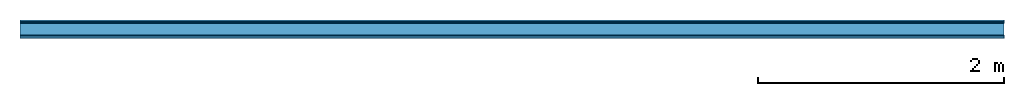
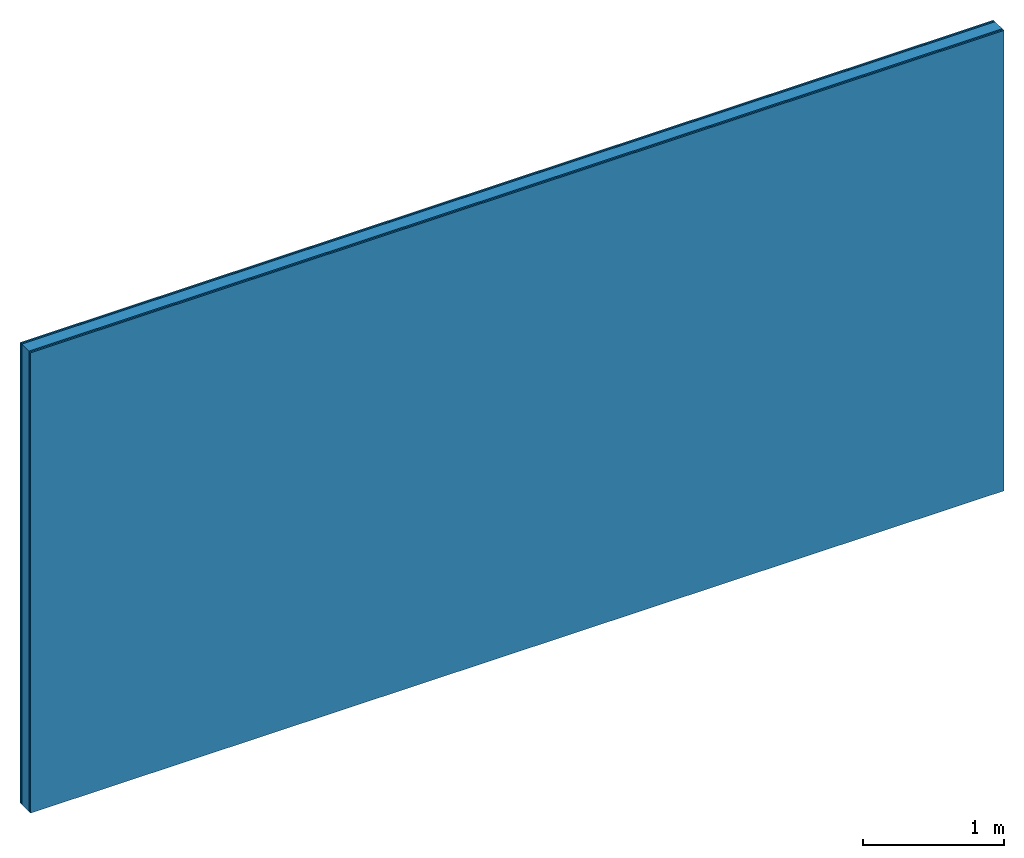
# One storey: 4 plates, 1 member, 1 element without a shape of its own.
"""IFC4 building model written with IfcOpenShell, lengths in metres."""

from ifc_helpers import new_model, si_unit, derived_unit, direction, frame, frame_2d, origin, origin_with_axes, place, context, project, spatial, rectangle, extrude, material, layer, layer_set, type_object, element, aggregate, save


model = new_model("IFC4")

# Units and contexts
plan_context = context("Plan", 3, precision=1e-05, world=origin(), true_north=direction((0.0, 1.0)))
model_context = context("Model", 3, precision=1e-05, world=origin(), true_north=direction((0.0, 1.0)))
ifc_project = project(units=[si_unit("LENGTHUNIT", "METRE"), derived_unit("SOUNDPRESSUREUNIT", [(si_unit("PRESSUREUNIT", "PASCAL", prefix="MICRO"), 0)]), si_unit("ENERGYUNIT", "JOULE", prefix="MEGA"), si_unit("MASSUNIT", "GRAM", prefix="KILO"), derived_unit("THERMALTRANSMITTANCEUNIT", [(si_unit("POWERUNIT", "WATT"), 1), (si_unit("AREAUNIT", "SQUARE_METRE"), -1), (si_unit("THERMODYNAMICTEMPERATUREUNIT", "KELVIN"), -1)]), derived_unit("AREADENSITYUNIT", [(si_unit("MASSUNIT", "GRAM", prefix="KILO"), 1), (si_unit("AREAUNIT", "SQUARE_METRE"), -1)]), derived_unit("USERDEFINED", [(si_unit("ENERGYUNIT", "JOULE", prefix="MEGA"), 1), (si_unit("AREAUNIT", "SQUARE_METRE"), -1)])], contexts=[plan_context, model_context])

# Site, building, storey
site = spatial("IfcSite", under=ifc_project)
building_placement = place(None, origin())
building = spatial("IfcBuilding", under=site, at=building_placement)
storey_placement = place(building_placement, origin())
storey = spatial("IfcBuildingStorey", under=building, at=storey_placement)

# Wall, member, plates
ifc_material_1 = material(Name="joints", Category="04.017")
ifc_layer_1 = layer(ifc_material_1, 0.0, Name="Surface")
ifc_material_2 = material(Name="Rigidur H", Category="03.007")
ifc_layer_2 = layer(ifc_material_2, 0.0125, Name="2nd layer")
ifc_layer_3 = layer(ifc_material_2, 0.0125, Name="1st layer")
ifc_material_3 = material(Name="of the art")
ifc_layer_4 = layer(ifc_material_3, 0.0, Name="Bond")
ifc_layer_5 = layer(None, 0.1, Name="Support")
ifc_layer_6 = layer(ifc_material_3, 0.0, Name="Bond")
ifc_layer_7 = layer(ifc_material_2, 0.0125, Name="1st layer")
ifc_layer_8 = layer(ifc_material_2, 0.0125, Name="2nd layer")
ifc_layer_9 = layer(ifc_material_1, 0.0, Name="Surface")
ifc_layer_set = layer_set([ifc_layer_1, ifc_layer_2, ifc_layer_3, ifc_layer_4, ifc_layer_5, ifc_layer_6, ifc_layer_7, ifc_layer_8, ifc_layer_9])
wall_type = type_object("IfcWallType", Name="C0473", PredefinedType="NOTDEFINED", material=ifc_layer_set)
wall_placement = place(None, frame((0.0, 0.0, 0.0), z_axis=(0.0, -1.0, 0.0), x_axis=(1.0, 0.0, 0.0)))
wall = element("IfcWall", 1, at=wall_placement, inside=storey, type_object=wall_type, material=ifc_layer_set, Name="Wall #1")
ifc_material_4 = material(Name="OSB")
member_placement = place(wall_placement, origin())
member = element("IfcMember", 2, at=member_placement, material=ifc_material_4, Name="Support", context=plan_context, shape_type="SweptSolid", body=[
    extrude(rectangle(XDim=1.0, YDim=0.1, at=frame_2d((0.5, 0.05), x_axis=(1.0, 0.0))), frame((0.0, 4.0, 0.025), z_axis=(0.0, -1.0, 0.0), x_axis=(1.0, 0.0, 0.0)), (0.0, 0.0, 1.0), 4.0),
    extrude(rectangle(XDim=1.0, YDim=0.1, at=frame_2d((0.5, 0.05), x_axis=(1.0, 0.0))), frame((1.0, 4.0, 0.025), z_axis=(0.0, -1.0, 0.0), x_axis=(1.0, 0.0, 0.0)), (0.0, 0.0, 1.0), 4.0),
    extrude(rectangle(XDim=1.0, YDim=0.1, at=frame_2d((0.5, 0.05), x_axis=(1.0, 0.0))), frame((2.0, 4.0, 0.025), z_axis=(0.0, -1.0, 0.0), x_axis=(1.0, 0.0, 0.0)), (0.0, 0.0, 1.0), 4.0),
    extrude(rectangle(XDim=1.0, YDim=0.1, at=frame_2d((0.5, 0.05), x_axis=(1.0, 0.0))), frame((3.0, 4.0, 0.025), z_axis=(0.0, -1.0, 0.0), x_axis=(1.0, 0.0, 0.0)), (0.0, 0.0, 1.0), 4.0),
    extrude(rectangle(XDim=1.0, YDim=0.1, at=frame_2d((0.5, 0.05), x_axis=(1.0, 0.0))), frame((4.0, 4.0, 0.025), z_axis=(0.0, -1.0, 0.0), x_axis=(1.0, 0.0, 0.0)), (0.0, 0.0, 1.0), 4.0),
    extrude(rectangle(XDim=1.0, YDim=0.1, at=frame_2d((0.5, 0.05), x_axis=(1.0, 0.0))), frame((5.0, 4.0, 0.025), z_axis=(0.0, -1.0, 0.0), x_axis=(1.0, 0.0, 0.0)), (0.0, 0.0, 1.0), 4.0),
    extrude(rectangle(XDim=1.0, YDim=0.1, at=frame_2d((0.5, 0.05), x_axis=(1.0, 0.0))), frame((6.0, 4.0, 0.025), z_axis=(0.0, -1.0, 0.0), x_axis=(1.0, 0.0, 0.0)), (0.0, 0.0, 1.0), 4.0),
    extrude(rectangle(XDim=1.0, YDim=0.1, at=frame_2d((0.5, 0.05), x_axis=(1.0, 0.0))), frame((7.0, 4.0, 0.025), z_axis=(0.0, -1.0, 0.0), x_axis=(1.0, 0.0, 0.0)), (0.0, 0.0, 1.0), 4.0),
])
plate_1_placement = place(wall_placement, origin())
plate_1 = element("IfcPlate", 3, at=plate_1_placement, material=ifc_material_2, Name="2nd layer", context=plan_context, shape_type="SweptSolid", body=[
    extrude(rectangle(XDim=8.0, YDim=4.0, at=frame_2d((4.0, 2.0), x_axis=(1.0, 0.0))), origin_with_axes(), (0.0, 0.0, 1.0), 0.0125),
])
plate_2_placement = place(wall_placement, origin())
plate_2 = element("IfcPlate", 4, at=plate_2_placement, material=ifc_material_2, Name="1st layer", context=plan_context, shape_type="SweptSolid", body=[
    extrude(rectangle(XDim=8.0, YDim=4.0, at=frame_2d((4.0, 2.0), x_axis=(1.0, 0.0))), frame((0.0, 0.0, 0.0125), z_axis=(0.0, 0.0, 1.0), x_axis=(1.0, 0.0, 0.0)), (0.0, 0.0, 1.0), 0.0125),
])
plate_3_placement = place(wall_placement, origin())
plate_3 = element("IfcPlate", 5, at=plate_3_placement, material=ifc_material_2, Name="1st layer", context=plan_context, shape_type="SweptSolid", body=[
    extrude(rectangle(XDim=8.0, YDim=4.0, at=frame_2d((4.0, 2.0), x_axis=(1.0, 0.0))), frame((0.0, 0.0, 0.125), z_axis=(0.0, 0.0, 1.0), x_axis=(1.0, 0.0, 0.0)), (0.0, 0.0, 1.0), 0.0125),
])
plate_4_placement = place(wall_placement, origin())
plate_4 = element("IfcPlate", 6, at=plate_4_placement, material=ifc_material_2, Name="2nd layer", context=plan_context, shape_type="SweptSolid", body=[
    extrude(rectangle(XDim=8.0, YDim=4.0, at=frame_2d((4.0, 2.0), x_axis=(1.0, 0.0))), frame((0.0, 0.0, 0.1375), z_axis=(0.0, 0.0, 1.0), x_axis=(1.0, 0.0, 0.0)), (0.0, 0.0, 1.0), 0.0125),
])
aggregate(wall, [plate_1, plate_2, member, plate_3, plate_4])

save(model, "model.ifc")
